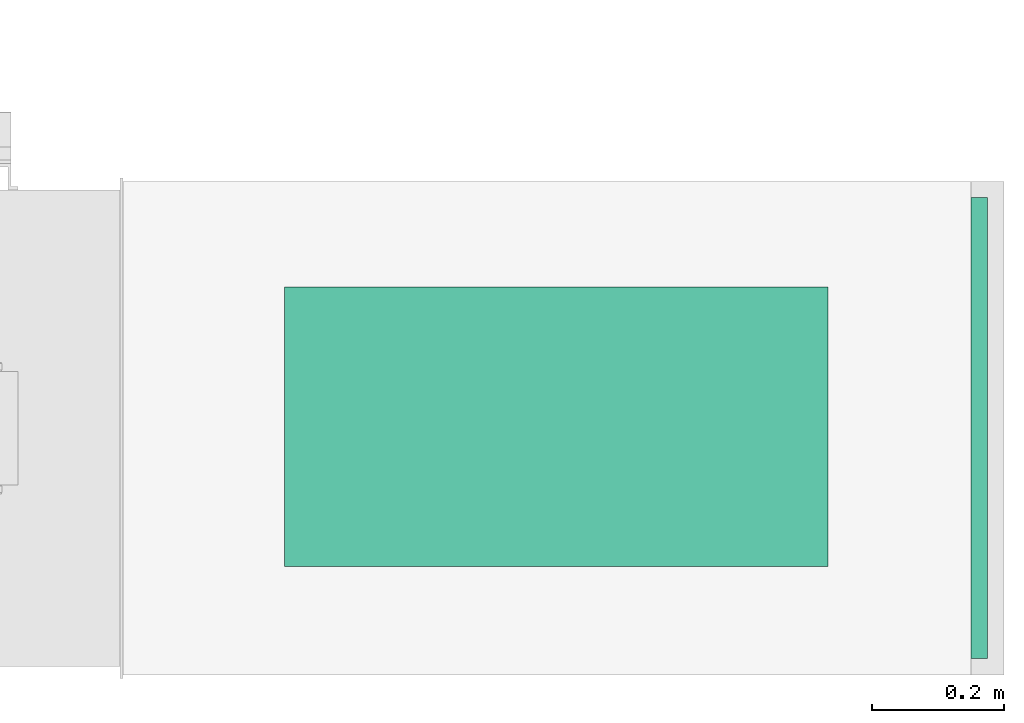
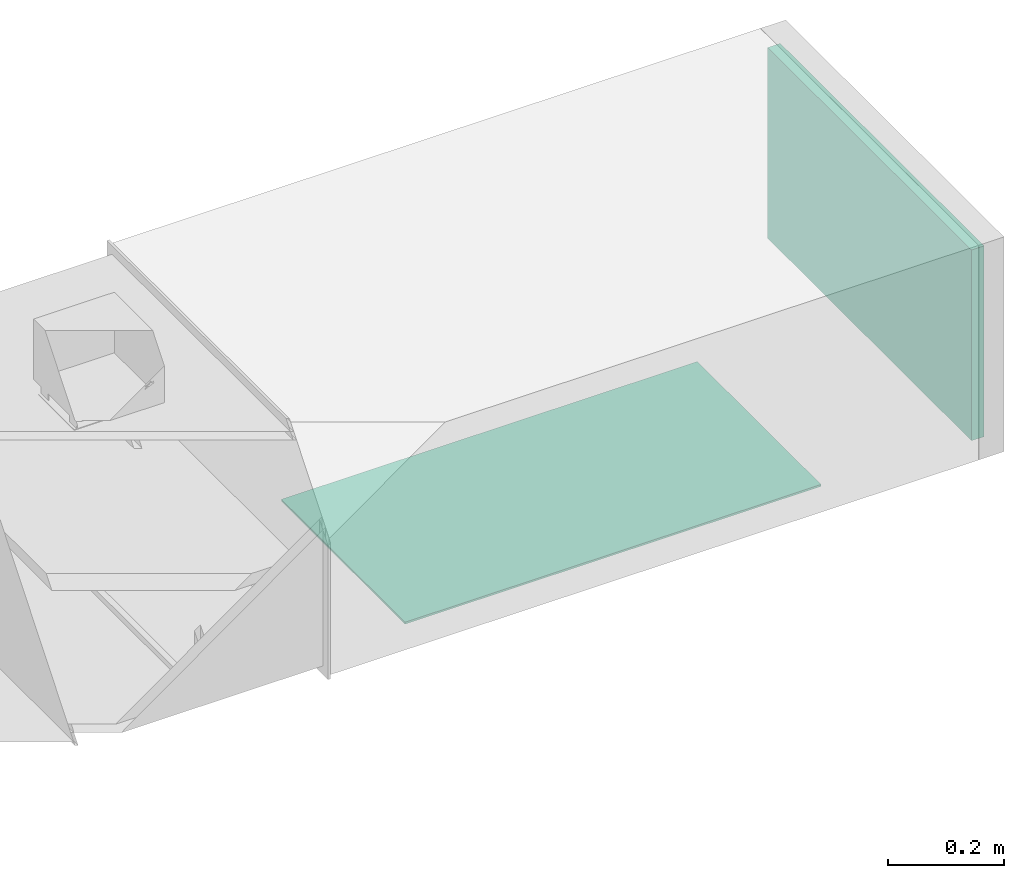
# One storey, part 5 of 8: 1 flow fitting, 1 flow terminal.
"""IFC2X3 building model written with IfcOpenShell, lengths in millimetres."""

from ifc_helpers import new_model, entity, si_unit, converted_unit, derived_unit, direction, frame, frame_2d, origin, origin_2d_with_axis, place, context, subcontext, project, spatial, rectangle, extrude, source, transform, mapped, material, type_object, type_shapes, element, save


model = new_model("IFC2X3")

# Units and contexts
model_context = context("Model", 3, precision=0.01, world=origin(), true_north=direction((6.12303176911189e-17, 1.0)))
body_context = subcontext(model_context, "Body", "Model", "MODEL_VIEW")
ifc_project = project(units=[si_unit("LENGTHUNIT", "METRE", prefix="MILLI"), si_unit("AREAUNIT", "SQUARE_METRE"), si_unit("VOLUMEUNIT", "CUBIC_METRE"), converted_unit("PLANEANGLEUNIT", "DEGREE", entity("IfcRatioMeasure", 0.0174532925199433), si_unit("PLANEANGLEUNIT", "RADIAN"), dimensions=[0, 0, 0, 0, 0, 0, 0]), si_unit("MASSUNIT", "GRAM", prefix="KILO"), derived_unit("MASSDENSITYUNIT", [(si_unit("MASSUNIT", "GRAM", prefix="KILO"), 1), (si_unit("LENGTHUNIT", "METRE"), -3)]), derived_unit("MOMENTOFINERTIAUNIT", [(si_unit("LENGTHUNIT", "METRE"), 4)]), si_unit("TIMEUNIT", "SECOND"), si_unit("FREQUENCYUNIT", "HERTZ"), si_unit("THERMODYNAMICTEMPERATUREUNIT", "DEGREE_CELSIUS"), derived_unit("THERMALTRANSMITTANCEUNIT", [(si_unit("MASSUNIT", "GRAM", prefix="KILO"), 1), (si_unit("THERMODYNAMICTEMPERATUREUNIT", "KELVIN"), -1), (si_unit("TIMEUNIT", "SECOND"), -3)]), derived_unit("VOLUMETRICFLOWRATEUNIT", [(si_unit("LENGTHUNIT", "METRE"), 3), (si_unit("TIMEUNIT", "SECOND"), -1)]), derived_unit("MASSFLOWRATEUNIT", [(si_unit("MASSUNIT", "GRAM", prefix="KILO"), 1), (si_unit("TIMEUNIT", "SECOND"), -1)]), derived_unit("ROTATIONALFREQUENCYUNIT", [(si_unit("TIMEUNIT", "SECOND"), -1)]), si_unit("ELECTRICCURRENTUNIT", "AMPERE"), si_unit("ELECTRICVOLTAGEUNIT", "VOLT"), si_unit("POWERUNIT", "WATT"), si_unit("FORCEUNIT", "NEWTON", prefix="KILO"), si_unit("ILLUMINANCEUNIT", "LUX"), si_unit("LUMINOUSFLUXUNIT", "LUMEN"), si_unit("LUMINOUSINTENSITYUNIT", "CANDELA"), derived_unit("USERDEFINED", [(si_unit("MASSUNIT", "GRAM", prefix="KILO"), -1), (si_unit("LENGTHUNIT", "METRE"), -2), (si_unit("TIMEUNIT", "SECOND"), 3), (si_unit("LUMINOUSFLUXUNIT", "LUMEN"), 1)]), derived_unit("LINEARVELOCITYUNIT", [(si_unit("LENGTHUNIT", "METRE"), 1), (si_unit("TIMEUNIT", "SECOND"), -1)]), si_unit("PRESSUREUNIT", "PASCAL"), derived_unit("USERDEFINED", [(si_unit("LENGTHUNIT", "METRE"), -2), (si_unit("MASSUNIT", "GRAM", prefix="KILO"), 1), (si_unit("TIMEUNIT", "SECOND"), -2)]), derived_unit("LINEARFORCEUNIT", [(si_unit("MASSUNIT", "GRAM", prefix="KILO"), 1), (si_unit("LENGTHUNIT", "METRE"), 1), (si_unit("TIMEUNIT", "SECOND"), -2), (si_unit("LENGTHUNIT", "METRE"), -1)]), derived_unit("PLANARFORCEUNIT", [(si_unit("MASSUNIT", "GRAM", prefix="KILO"), 1), (si_unit("LENGTHUNIT", "METRE"), 1), (si_unit("TIMEUNIT", "SECOND"), -2), (si_unit("LENGTHUNIT", "METRE"), -2)])], contexts=[model_context])

# Site, building, storey
site_placement = place(None, frame((0.0, -0.00077364408347762, 0.0)))
site = spatial("IfcSite", under=ifc_project, at=site_placement, CompositionType="ELEMENT")
building_placement = place(site_placement, origin())
building = spatial("IfcBuilding", under=site, at=building_placement, CompositionType="ELEMENT")
storey_placement = place(building_placement, frame((0.0, 0.0, 4200.0)))
storey = spatial("IfcBuildingStorey", under=building, at=storey_placement, CompositionType="ELEMENT", Elevation=4200.0)

# Flow fitting
ifc_material_1 = material()
duct_fitting_type = type_object("IfcDuctFittingType", PredefinedType="NOTDEFINED", material=ifc_material_1)
shared_shape_1 = source(origin(), body_context, "Body", "SweptSolid", [
    extrude(rectangle(XDim=24.9999999999999, YDim=700.0, at=frame_2d((-2.89546164822241e-13, 5.6843418860808e-14), x_axis=(1.0, 0.0))), frame((12.500000000006, 0.0, -200.0)), (0.0, 0.0, 1.0), 400.0),
])
type_shapes(duct_fitting_type, [shared_shape_1])
flow_fitting_placement = place(storey_placement, frame((65397.9985523545, 9835.42147047355, 2700.0)))
element("IfcFlowFitting", 1, at=flow_fitting_placement, inside=storey, type_object=duct_fitting_type, material=ifc_material_1, context=body_context, shape_type="MappedRepresentation", body=[
    mapped(shared_shape_1, transform((0.0, 0.0, 0.0), scale=1.0)),
])

# Flow terminal
ifc_material_2 = material()
air_terminal_type = type_object("IfcAirTerminalType", PredefinedType="NOTDEFINED", material=ifc_material_2)
shared_shape_2 = source(origin(), body_context, "Body", "SweptSolid", [
    extrude(rectangle(XDim=4.0, YDim=824.999999999999, at=origin_2d_with_axis()), frame((0.0, -2.0, -212.500000000002), z_axis=(0.0, 0.0, 1.0), x_axis=(0.0, 1.0, 0.0)), (0.0, 0.0, 1.0), 425.000000000005),
])
type_shapes(air_terminal_type, [shared_shape_2])
flow_terminal_placement = place(storey_placement, frame((64767.8625351618, 9837.55544364408, 2400.0), z_axis=(0.0, -1.0, 0.0), x_axis=(1.0, 0.0, 0.0)))
element("IfcFlowTerminal", 2, at=flow_terminal_placement, inside=storey, type_object=air_terminal_type, material=ifc_material_2, context=body_context, shape_type="MappedRepresentation", body=[
    mapped(shared_shape_2, transform((0.0, 0.0, 0.0), scale=1.0)),
])

save(model, "model.ifc")
